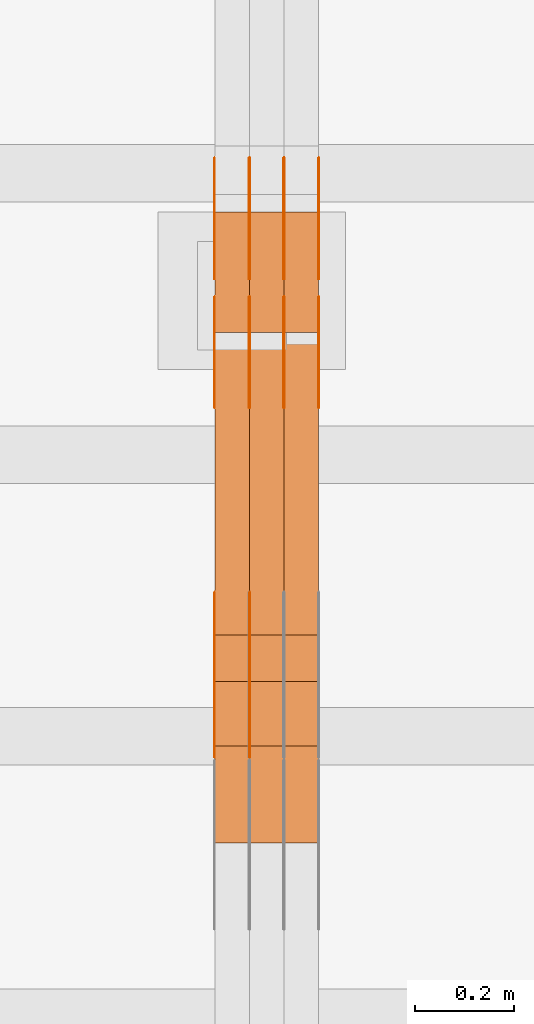
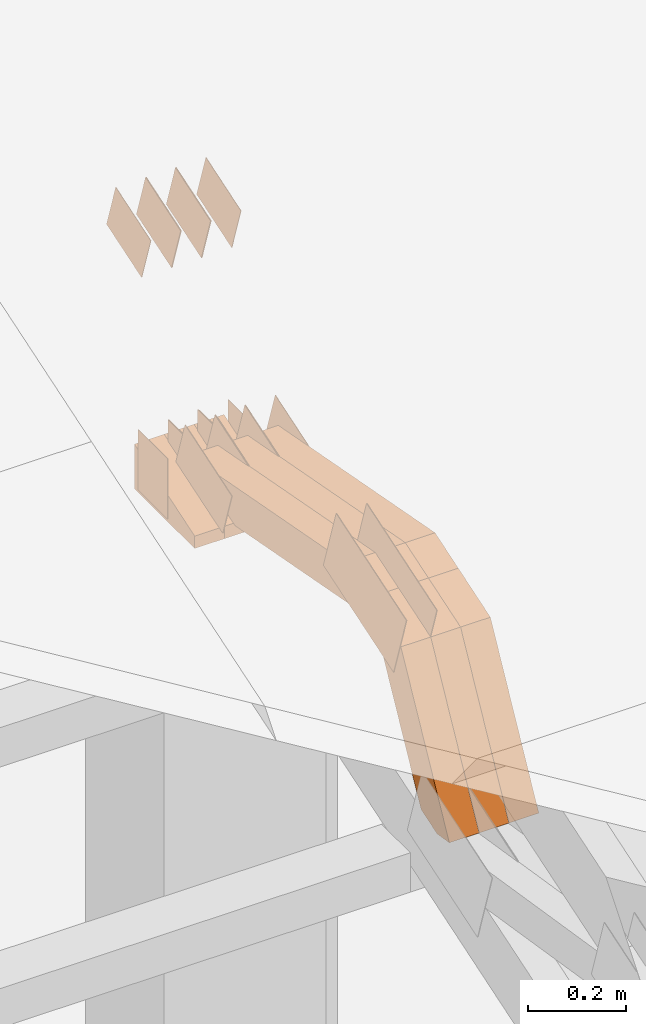
# One storey, part 95 of 385: 29 proxies.
"""IFC2X3 building model written with IfcOpenShell, lengths in millimetres."""

from ifc_helpers import new_model, entity, si_unit, converted_unit, derived_unit, direction, frame, frame_2d, origin, place, context, subcontext, project, spatial, polyline, rectangle, outline, extrude, source, transform, mapped, material, type_object, type_shapes, element, save


model = new_model("IFC2X3")

# Units and contexts
model_context = context("Model", 3, precision=0.01, world=origin(), true_north=direction((6.12303176911189e-17, 1.0)))
body_context = subcontext(model_context, "Body", "Model", "MODEL_VIEW")
ifc_project = project(units=[si_unit("LENGTHUNIT", "METRE", prefix="MILLI"), si_unit("AREAUNIT", "SQUARE_METRE"), si_unit("VOLUMEUNIT", "CUBIC_METRE"), converted_unit("PLANEANGLEUNIT", "DEGREE", entity("IfcRatioMeasure", 0.0174532925199433), si_unit("PLANEANGLEUNIT", "RADIAN"), dimensions=[0, 0, 0, 0, 0, 0, 0]), si_unit("MASSUNIT", "GRAM", prefix="KILO"), derived_unit("MASSDENSITYUNIT", [(si_unit("MASSUNIT", "GRAM", prefix="KILO"), 1), (si_unit("LENGTHUNIT", "METRE"), -3)]), si_unit("TIMEUNIT", "SECOND"), si_unit("FREQUENCYUNIT", "HERTZ"), si_unit("THERMODYNAMICTEMPERATUREUNIT", "DEGREE_CELSIUS"), derived_unit("THERMALTRANSMITTANCEUNIT", [(si_unit("MASSUNIT", "GRAM", prefix="KILO"), 1), (si_unit("THERMODYNAMICTEMPERATUREUNIT", "KELVIN"), -1), (si_unit("TIMEUNIT", "SECOND"), -3)]), derived_unit("VOLUMETRICFLOWRATEUNIT", [(si_unit("LENGTHUNIT", "METRE"), 3), (si_unit("TIMEUNIT", "SECOND"), -1)]), si_unit("ELECTRICCURRENTUNIT", "AMPERE"), si_unit("ELECTRICVOLTAGEUNIT", "VOLT"), si_unit("POWERUNIT", "WATT"), si_unit("FORCEUNIT", "NEWTON", prefix="KILO"), si_unit("ILLUMINANCEUNIT", "LUX"), si_unit("LUMINOUSFLUXUNIT", "LUMEN"), si_unit("LUMINOUSINTENSITYUNIT", "CANDELA"), derived_unit("USERDEFINED", [(si_unit("MASSUNIT", "GRAM", prefix="KILO"), -1), (si_unit("LENGTHUNIT", "METRE"), -2), (si_unit("TIMEUNIT", "SECOND"), 3), (si_unit("LUMINOUSFLUXUNIT", "LUMEN"), 1)]), derived_unit("LINEARVELOCITYUNIT", [(si_unit("LENGTHUNIT", "METRE"), 1), (si_unit("TIMEUNIT", "SECOND"), -1)]), si_unit("PRESSUREUNIT", "PASCAL"), derived_unit("USERDEFINED", [(si_unit("LENGTHUNIT", "METRE"), -2), (si_unit("MASSUNIT", "GRAM", prefix="KILO"), 1), (si_unit("TIMEUNIT", "SECOND"), -2)])], contexts=[model_context])

# Site, building, storey
site_placement = place(None, origin())
site = spatial("IfcSite", under=ifc_project, at=site_placement, CompositionType="ELEMENT")
building_placement = place(site_placement, origin())
building = spatial("IfcBuilding", under=site, at=building_placement, CompositionType="ELEMENT")
storey_placement = place(building_placement, origin())
storey = spatial("IfcBuildingStorey", under=building, at=storey_placement, Name="Default", CompositionType="ELEMENT", Elevation=0.0)

# Proxies
ifc_material_1 = material(Name="IfcSurfaceStyle #207088")
building_element_proxy_type_1 = type_object("IfcBuildingElementProxyType", PredefinedType="NOTDEFINED", material=ifc_material_1)
shared_shape_1 = source(origin(), body_context, "Body", "SweptSolid", [
    extrude(outline(polyline([(-99.9997874178038, -60.0000528641967), (99.9998102700997, -60.0000528641967), (99.9998251396068, 60.0000528641967), (-99.9998479919027, 60.0000528641967), (-99.9997874178038, -60.0000528641967)])), frame((99.9999918898597, 60.0000528641967, 0.0), z_axis=(0.0, 0.0, 1.0), x_axis=(-1.0, 0.0, 0.0)), (0.0, 0.0, 1.0), 1.3),
])
type_shapes(building_element_proxy_type_1, [shared_shape_1])
proxy_1_placement = place(building_placement, frame((15386.3, 11991.9568177725, 3072.52282247925), z_axis=(-1.0, 0.0, 0.0), x_axis=(0.0, 0.951056516295124, 0.309016994375039)))
element("IfcBuildingElementProxy", 1, at=proxy_1_placement, inside=storey, type_object=building_element_proxy_type_1, material=ifc_material_1, context=body_context, shape_type="MappedRepresentation", body=[
    mapped(shared_shape_1, transform((0.0, 0.0, 0.0), scale=1.0)),
])
ifc_material_2 = material(Name="IfcSurfaceStyle #207031")
building_element_proxy_type_2 = type_object("IfcBuildingElementProxyType", PredefinedType="NOTDEFINED", material=ifc_material_2)
shared_shape_2 = source(origin(), body_context, "Body", "SweptSolid", [
    extrude(outline(polyline([(-99.9997874178038, -60.0000528641967), (99.9998102700997, -60.0000528641967), (99.9998251396068, 60.0000528641967), (-99.9998479919027, 60.0000528641967), (-99.9997874178038, -60.0000528641967)])), frame((99.9999918898597, 60.0000528641967, 0.0), z_axis=(0.0, 0.0, 1.0), x_axis=(-1.0, 0.0, 0.0)), (0.0, 0.0, 1.0), 1.3),
])
type_shapes(building_element_proxy_type_2, [shared_shape_2])
proxy_2_placement = place(building_placement, frame((15315.0, 11991.9568177725, 3072.52282247925), z_axis=(-1.0, 0.0, 0.0), x_axis=(0.0, 0.951056516295124, 0.309016994375039)))
element("IfcBuildingElementProxy", 2, at=proxy_2_placement, inside=storey, type_object=building_element_proxy_type_2, material=ifc_material_2, context=body_context, shape_type="MappedRepresentation", body=[
    mapped(shared_shape_2, transform((0.0, 0.0, 0.0), scale=1.0)),
])
ifc_material_3 = material(Name="IfcSurfaceStyle #206974")
building_element_proxy_type_3 = type_object("IfcBuildingElementProxyType", PredefinedType="NOTDEFINED", material=ifc_material_3)
shared_shape_3 = source(origin(), body_context, "Body", "SweptSolid", [
    extrude(outline(polyline([(-99.9997874178038, -60.0000528641967), (99.9998102700997, -60.0000528641967), (99.9998251396068, 60.0000528641967), (-99.9998479919027, 60.0000528641967), (-99.9997874178038, -60.0000528641967)])), frame((99.9999918898597, 60.0000528641967, 0.0), z_axis=(0.0, 0.0, 1.0), x_axis=(-1.0, 0.0, 0.0)), (0.0, 0.0, 1.0), 1.3),
])
type_shapes(building_element_proxy_type_3, [shared_shape_3])
proxy_3_placement = place(building_placement, frame((15316.3, 11991.9568177725, 3072.52282247925), z_axis=(-1.0, 0.0, 0.0), x_axis=(0.0, 0.951056516295124, 0.309016994375039)))
element("IfcBuildingElementProxy", 3, at=proxy_3_placement, inside=storey, type_object=building_element_proxy_type_3, material=ifc_material_3, context=body_context, shape_type="MappedRepresentation", body=[
    mapped(shared_shape_3, transform((0.0, 0.0, 0.0), scale=1.0)),
])
ifc_material_4 = material(Name="IfcSurfaceStyle #206917")
building_element_proxy_type_4 = type_object("IfcBuildingElementProxyType", PredefinedType="NOTDEFINED", material=ifc_material_4)
shared_shape_4 = source(origin(), body_context, "Body", "SweptSolid", [
    extrude(outline(polyline([(-99.9997874178038, -60.0000528641967), (99.9998102700997, -60.0000528641967), (99.9998251396068, 60.0000528641967), (-99.9998479919027, 60.0000528641967), (-99.9997874178038, -60.0000528641967)])), frame((99.9999918898597, 60.0000528641967, 0.0), z_axis=(0.0, 0.0, 1.0), x_axis=(-1.0, 0.0, 0.0)), (0.0, 0.0, 1.0), 1.29999999999998),
])
type_shapes(building_element_proxy_type_4, [shared_shape_4])
proxy_4_placement = place(building_placement, frame((15245.0, 11991.9568177725, 3072.52282247925), z_axis=(-1.0, 0.0, 0.0), x_axis=(0.0, 0.951056516295124, 0.309016994375039)))
element("IfcBuildingElementProxy", 4, at=proxy_4_placement, inside=storey, type_object=building_element_proxy_type_4, material=ifc_material_4, context=body_context, shape_type="MappedRepresentation", body=[
    mapped(shared_shape_4, transform((0.0, 0.0, 0.0), scale=1.0)),
])
ifc_material_5 = material(Name="IfcSurfaceStyle #206860")
building_element_proxy_type_5 = type_object("IfcBuildingElementProxyType", PredefinedType="NOTDEFINED", material=ifc_material_5)
shared_shape_5 = source(origin(), body_context, "Body", "SweptSolid", [
    extrude(outline(polyline([(-99.9997874178038, -60.0000528641967), (99.9998102700997, -60.0000528641967), (99.9998251396068, 60.0000528641967), (-99.9998479919027, 60.0000528641967), (-99.9997874178038, -60.0000528641967)])), frame((99.9999918898597, 60.0000528641967, 0.0), z_axis=(0.0, 0.0, 1.0), x_axis=(-1.0, 0.0, 0.0)), (0.0, 0.0, 1.0), 1.29999999999998),
])
type_shapes(building_element_proxy_type_5, [shared_shape_5])
proxy_5_placement = place(building_placement, frame((15246.3, 11991.9568177725, 3072.52282247925), z_axis=(-1.0, 0.0, 0.0), x_axis=(0.0, 0.951056516295124, 0.309016994375039)))
element("IfcBuildingElementProxy", 5, at=proxy_5_placement, inside=storey, type_object=building_element_proxy_type_5, material=ifc_material_5, context=body_context, shape_type="MappedRepresentation", body=[
    mapped(shared_shape_5, transform((0.0, 0.0, 0.0), scale=1.0)),
])
ifc_material_6 = material(Name="IfcSurfaceStyle #206803")
building_element_proxy_type_6 = type_object("IfcBuildingElementProxyType", PredefinedType="NOTDEFINED", material=ifc_material_6)
shared_shape_6 = source(origin(), body_context, "Body", "SweptSolid", [
    extrude(outline(polyline([(-99.9997874178038, -60.0000528641967), (99.9998102700997, -60.0000528641967), (99.9998251396068, 60.0000528641967), (-99.9998479919027, 60.0000528641967), (-99.9997874178038, -60.0000528641967)])), frame((99.9999918898597, 60.0000528641967, 0.0), z_axis=(0.0, 0.0, 1.0), x_axis=(-1.0, 0.0, 0.0)), (0.0, 0.0, 1.0), 1.29999999999999),
])
type_shapes(building_element_proxy_type_6, [shared_shape_6])
proxy_6_placement = place(building_placement, frame((15175.0, 11991.9568177725, 3072.52282247925), z_axis=(-1.0, 0.0, 0.0), x_axis=(0.0, 0.951056516295124, 0.309016994375039)))
element("IfcBuildingElementProxy", 6, at=proxy_6_placement, inside=storey, type_object=building_element_proxy_type_6, material=ifc_material_6, context=body_context, shape_type="MappedRepresentation", body=[
    mapped(shared_shape_6, transform((0.0, 0.0, 0.0), scale=1.0)),
])
ifc_material_7 = material(Name="IfcSurfaceStyle #206746")
building_element_proxy_type_7 = type_object("IfcBuildingElementProxyType", PredefinedType="NOTDEFINED", material=ifc_material_7)
shared_shape_7 = source(origin(), body_context, "Body", "SweptSolid", [
    extrude(rectangle(XDim=150.0, YDim=119.999999999985, at=frame_2d((-7.105427357601e-15, 0.0), x_axis=(1.0, 0.0))), frame((75.0, 60.0, 0.0), z_axis=(0.0, 0.0, 1.0), x_axis=(-1.0, 0.0, 0.0)), (0.0, 0.0, 1.0), 1.3),
])
type_shapes(building_element_proxy_type_7, [shared_shape_7])
proxy_7_placement = place(building_placement, frame((15386.3, 12372.95703125, 3007.04687500001), z_axis=(-1.0, 0.0, 0.0), x_axis=(0.0, 0.0, -1.0)))
element("IfcBuildingElementProxy", 7, at=proxy_7_placement, inside=storey, type_object=building_element_proxy_type_7, material=ifc_material_7, context=body_context, shape_type="MappedRepresentation", body=[
    mapped(shared_shape_7, transform((0.0, 0.0, 0.0), scale=1.0)),
])
ifc_material_8 = material(Name="IfcSurfaceStyle #206689")
building_element_proxy_type_8 = type_object("IfcBuildingElementProxyType", PredefinedType="NOTDEFINED", material=ifc_material_8)
shared_shape_8 = source(origin(), body_context, "Body", "SweptSolid", [
    extrude(rectangle(XDim=150.0, YDim=119.999999999985, at=frame_2d((-7.105427357601e-15, 0.0), x_axis=(1.0, 0.0))), frame((75.0, 60.0, 0.0), z_axis=(0.0, 0.0, 1.0), x_axis=(-1.0, 0.0, 0.0)), (0.0, 0.0, 1.0), 1.3),
])
type_shapes(building_element_proxy_type_8, [shared_shape_8])
proxy_8_placement = place(building_placement, frame((15315.0, 12372.95703125, 3007.04687500001), z_axis=(-1.0, 0.0, 0.0), x_axis=(0.0, 0.0, -1.0)))
element("IfcBuildingElementProxy", 8, at=proxy_8_placement, inside=storey, type_object=building_element_proxy_type_8, material=ifc_material_8, context=body_context, shape_type="MappedRepresentation", body=[
    mapped(shared_shape_8, transform((0.0, 0.0, 0.0), scale=1.0)),
])
ifc_material_9 = material(Name="IfcSurfaceStyle #206632")
building_element_proxy_type_9 = type_object("IfcBuildingElementProxyType", PredefinedType="NOTDEFINED", material=ifc_material_9)
shared_shape_9 = source(origin(), body_context, "Body", "SweptSolid", [
    extrude(rectangle(XDim=150.0, YDim=119.999999999985, at=frame_2d((-7.105427357601e-15, 0.0), x_axis=(1.0, 0.0))), frame((75.0, 60.0, 0.0), z_axis=(0.0, 0.0, 1.0), x_axis=(-1.0, 0.0, 0.0)), (0.0, 0.0, 1.0), 1.3),
])
type_shapes(building_element_proxy_type_9, [shared_shape_9])
proxy_9_placement = place(building_placement, frame((15316.3, 12372.95703125, 3007.04687500001), z_axis=(-1.0, 0.0, 0.0), x_axis=(0.0, 0.0, -1.0)))
element("IfcBuildingElementProxy", 9, at=proxy_9_placement, inside=storey, type_object=building_element_proxy_type_9, material=ifc_material_9, context=body_context, shape_type="MappedRepresentation", body=[
    mapped(shared_shape_9, transform((0.0, 0.0, 0.0), scale=1.0)),
])
ifc_material_10 = material(Name="IfcSurfaceStyle #206575")
building_element_proxy_type_10 = type_object("IfcBuildingElementProxyType", PredefinedType="NOTDEFINED", material=ifc_material_10)
shared_shape_10 = source(origin(), body_context, "Body", "SweptSolid", [
    extrude(rectangle(XDim=150.0, YDim=119.999999999985, at=frame_2d((-7.105427357601e-15, 0.0), x_axis=(1.0, 0.0))), frame((75.0, 60.0, 0.0), z_axis=(0.0, 0.0, 1.0), x_axis=(-1.0, 0.0, 0.0)), (0.0, 0.0, 1.0), 1.29999999999999),
])
type_shapes(building_element_proxy_type_10, [shared_shape_10])
proxy_10_placement = place(building_placement, frame((15245.0, 12372.95703125, 3007.04687500001), z_axis=(-1.0, 0.0, 0.0), x_axis=(0.0, 0.0, -1.0)))
element("IfcBuildingElementProxy", 10, at=proxy_10_placement, inside=storey, type_object=building_element_proxy_type_10, material=ifc_material_10, context=body_context, shape_type="MappedRepresentation", body=[
    mapped(shared_shape_10, transform((0.0, 0.0, 0.0), scale=1.0)),
])
ifc_material_11 = material(Name="IfcSurfaceStyle #206518")
building_element_proxy_type_11 = type_object("IfcBuildingElementProxyType", PredefinedType="NOTDEFINED", material=ifc_material_11)
shared_shape_11 = source(origin(), body_context, "Body", "SweptSolid", [
    extrude(rectangle(XDim=150.0, YDim=119.999999999985, at=frame_2d((-7.105427357601e-15, 0.0), x_axis=(1.0, 0.0))), frame((75.0, 60.0, 0.0), z_axis=(0.0, 0.0, 1.0), x_axis=(-1.0, 0.0, 0.0)), (0.0, 0.0, 1.0), 1.29999999999999),
])
type_shapes(building_element_proxy_type_11, [shared_shape_11])
proxy_11_placement = place(building_placement, frame((15246.3, 12372.95703125, 3007.04687500001), z_axis=(-1.0, 0.0, 0.0), x_axis=(0.0, 0.0, -1.0)))
element("IfcBuildingElementProxy", 11, at=proxy_11_placement, inside=storey, type_object=building_element_proxy_type_11, material=ifc_material_11, context=body_context, shape_type="MappedRepresentation", body=[
    mapped(shared_shape_11, transform((0.0, 0.0, 0.0), scale=1.0)),
])
ifc_material_12 = material(Name="IfcSurfaceStyle #206461")
building_element_proxy_type_12 = type_object("IfcBuildingElementProxyType", PredefinedType="NOTDEFINED", material=ifc_material_12)
shared_shape_12 = source(origin(), body_context, "Body", "SweptSolid", [
    extrude(rectangle(XDim=150.0, YDim=119.999999999985, at=frame_2d((-7.105427357601e-15, 0.0), x_axis=(1.0, 0.0))), frame((75.0, 60.0, 0.0), z_axis=(0.0, 0.0, 1.0), x_axis=(-1.0, 0.0, 0.0)), (0.0, 0.0, 1.0), 1.29999999999999),
])
type_shapes(building_element_proxy_type_12, [shared_shape_12])
proxy_12_placement = place(building_placement, frame((15175.0, 12372.95703125, 3007.04687500001), z_axis=(-1.0, 0.0, 0.0), x_axis=(0.0, 0.0, -1.0)))
element("IfcBuildingElementProxy", 12, at=proxy_12_placement, inside=storey, type_object=building_element_proxy_type_12, material=ifc_material_12, context=body_context, shape_type="MappedRepresentation", body=[
    mapped(shared_shape_12, transform((0.0, 0.0, 0.0), scale=1.0)),
])
ifc_material_13 = material(Name="IfcSurfaceStyle #199564")
building_element_proxy_type_13 = type_object("IfcBuildingElementProxyType", PredefinedType="NOTDEFINED", material=ifc_material_13)
shared_shape_13 = source(origin(), body_context, "Body", "SweptSolid", [
    extrude(outline(polyline([(-74.9998754286244, -60.0000016373506), (74.9998605591063, -60.0000016373506), (74.9998754286244, 60.0000016373506), (-74.9998605591063, 60.0000016373506), (-74.9998754286244, -60.0000016373506)])), frame((74.9998754286244, 60.0000016373506, 0.0), z_axis=(0.0, 0.0, 1.0), x_axis=(-1.0, 0.0, 0.0)), (0.0, 0.0, 1.0), 1.3),
])
type_shapes(building_element_proxy_type_13, [shared_shape_13])
proxy_13_placement = place(building_placement, frame((15386.3, 12321.1620861463, 3506.17707344366), z_axis=(-1.0, 0.0, 0.0), x_axis=(0.0, 0.951056516295154, 0.309016994374948)))
element("IfcBuildingElementProxy", 13, at=proxy_13_placement, inside=storey, type_object=building_element_proxy_type_13, material=ifc_material_13, context=body_context, shape_type="MappedRepresentation", body=[
    mapped(shared_shape_13, transform((0.0, 0.0, 0.0), scale=1.0)),
])
ifc_material_14 = material(Name="IfcSurfaceStyle #199507")
building_element_proxy_type_14 = type_object("IfcBuildingElementProxyType", PredefinedType="NOTDEFINED", material=ifc_material_14)
shared_shape_14 = source(origin(), body_context, "Body", "SweptSolid", [
    extrude(outline(polyline([(-74.9998754286244, -60.0000016373506), (74.9998605591063, -60.0000016373506), (74.9998754286244, 60.0000016373506), (-74.9998605591063, 60.0000016373506), (-74.9998754286244, -60.0000016373506)])), frame((74.9998754286244, 60.0000016373506, 0.0), z_axis=(0.0, 0.0, 1.0), x_axis=(-1.0, 0.0, 0.0)), (0.0, 0.0, 1.0), 1.3),
])
type_shapes(building_element_proxy_type_14, [shared_shape_14])
proxy_14_placement = place(building_placement, frame((15315.0, 12321.1620861463, 3506.17707344366), z_axis=(-1.0, 0.0, 0.0), x_axis=(0.0, 0.951056516295154, 0.309016994374948)))
element("IfcBuildingElementProxy", 14, at=proxy_14_placement, inside=storey, type_object=building_element_proxy_type_14, material=ifc_material_14, context=body_context, shape_type="MappedRepresentation", body=[
    mapped(shared_shape_14, transform((0.0, 0.0, 0.0), scale=1.0)),
])
ifc_material_15 = material(Name="IfcSurfaceStyle #199450")
building_element_proxy_type_15 = type_object("IfcBuildingElementProxyType", PredefinedType="NOTDEFINED", material=ifc_material_15)
shared_shape_15 = source(origin(), body_context, "Body", "SweptSolid", [
    extrude(outline(polyline([(-74.9998754286244, -60.0000016373506), (74.9998605591063, -60.0000016373506), (74.9998754286244, 60.0000016373506), (-74.9998605591063, 60.0000016373506), (-74.9998754286244, -60.0000016373506)])), frame((74.9998754286244, 60.0000016373506, 0.0), z_axis=(0.0, 0.0, 1.0), x_axis=(-1.0, 0.0, 0.0)), (0.0, 0.0, 1.0), 1.3),
])
type_shapes(building_element_proxy_type_15, [shared_shape_15])
proxy_15_placement = place(building_placement, frame((15316.3, 12321.1620861463, 3506.17707344366), z_axis=(-1.0, 0.0, 0.0), x_axis=(0.0, 0.951056516295154, 0.309016994374948)))
element("IfcBuildingElementProxy", 15, at=proxy_15_placement, inside=storey, type_object=building_element_proxy_type_15, material=ifc_material_15, context=body_context, shape_type="MappedRepresentation", body=[
    mapped(shared_shape_15, transform((0.0, 0.0, 0.0), scale=1.0)),
])
ifc_material_16 = material(Name="IfcSurfaceStyle #199393")
building_element_proxy_type_16 = type_object("IfcBuildingElementProxyType", PredefinedType="NOTDEFINED", material=ifc_material_16)
shared_shape_16 = source(origin(), body_context, "Body", "SweptSolid", [
    extrude(outline(polyline([(-74.9998754286244, -60.0000016373506), (74.9998605591063, -60.0000016373506), (74.9998754286244, 60.0000016373506), (-74.9998605591063, 60.0000016373506), (-74.9998754286244, -60.0000016373506)])), frame((74.9998754286244, 60.0000016373506, 0.0), z_axis=(0.0, 0.0, 1.0), x_axis=(-1.0, 0.0, 0.0)), (0.0, 0.0, 1.0), 1.29999999999999),
])
type_shapes(building_element_proxy_type_16, [shared_shape_16])
proxy_16_placement = place(building_placement, frame((15245.0, 12321.1620861463, 3506.17707344366), z_axis=(-1.0, 0.0, 0.0), x_axis=(0.0, 0.951056516295154, 0.309016994374948)))
element("IfcBuildingElementProxy", 16, at=proxy_16_placement, inside=storey, type_object=building_element_proxy_type_16, material=ifc_material_16, context=body_context, shape_type="MappedRepresentation", body=[
    mapped(shared_shape_16, transform((0.0, 0.0, 0.0), scale=1.0)),
])
ifc_material_17 = material(Name="IfcSurfaceStyle #199336")
building_element_proxy_type_17 = type_object("IfcBuildingElementProxyType", PredefinedType="NOTDEFINED", material=ifc_material_17)
shared_shape_17 = source(origin(), body_context, "Body", "SweptSolid", [
    extrude(outline(polyline([(-74.9998754286244, -60.0000016373506), (74.9998605591063, -60.0000016373506), (74.9998754286244, 60.0000016373506), (-74.9998605591063, 60.0000016373506), (-74.9998754286244, -60.0000016373506)])), frame((74.9998754286244, 60.0000016373506, 0.0), z_axis=(0.0, 0.0, 1.0), x_axis=(-1.0, 0.0, 0.0)), (0.0, 0.0, 1.0), 1.29999999999999),
])
type_shapes(building_element_proxy_type_17, [shared_shape_17])
proxy_17_placement = place(building_placement, frame((15246.3, 12321.1620861463, 3506.17707344366), z_axis=(-1.0, 0.0, 0.0), x_axis=(0.0, 0.951056516295154, 0.309016994374948)))
element("IfcBuildingElementProxy", 17, at=proxy_17_placement, inside=storey, type_object=building_element_proxy_type_17, material=ifc_material_17, context=body_context, shape_type="MappedRepresentation", body=[
    mapped(shared_shape_17, transform((0.0, 0.0, 0.0), scale=1.0)),
])
ifc_material_18 = material(Name="IfcSurfaceStyle #199279")
building_element_proxy_type_18 = type_object("IfcBuildingElementProxyType", PredefinedType="NOTDEFINED", material=ifc_material_18)
shared_shape_18 = source(origin(), body_context, "Body", "SweptSolid", [
    extrude(outline(polyline([(-74.9998754286244, -60.0000016373506), (74.9998605591063, -60.0000016373506), (74.9998754286244, 60.0000016373506), (-74.9998605591063, 60.0000016373506), (-74.9998754286244, -60.0000016373506)])), frame((74.9998754286244, 60.0000016373506, 0.0), z_axis=(0.0, 0.0, 1.0), x_axis=(-1.0, 0.0, 0.0)), (0.0, 0.0, 1.0), 1.29999999999999),
])
type_shapes(building_element_proxy_type_18, [shared_shape_18])
proxy_18_placement = place(building_placement, frame((15175.0, 12321.1620861463, 3506.17707344366), z_axis=(-1.0, 0.0, 0.0), x_axis=(0.0, 0.951056516295154, 0.309016994374948)))
element("IfcBuildingElementProxy", 18, at=proxy_18_placement, inside=storey, type_object=building_element_proxy_type_18, material=ifc_material_18, context=body_context, shape_type="MappedRepresentation", body=[
    mapped(shared_shape_18, transform((0.0, 0.0, 0.0), scale=1.0)),
])
ifc_material_19 = material(Name="IfcSurfaceStyle #198652")
building_element_proxy_type_19 = type_object("IfcBuildingElementProxyType", PredefinedType="NOTDEFINED", material=ifc_material_19)
shared_shape_19 = source(origin(), body_context, "Body", "SweptSolid", [
    extrude(outline(polyline([(-150.000273478628, -84.0002987844282), (149.999198496832, -84.0002987844282), (150.000273478627, 84.0002987844282), (-149.999198496831, 84.0002987844282), (-150.000273478628, -84.0002987844282)])), frame((150.000273478627, 84.0002987844282, 0.0), z_axis=(0.0, 0.0, 1.0), x_axis=(-1.0, 0.0, 0.0)), (0.0, 0.0, 1.0), 1.29999999999998),
])
type_shapes(building_element_proxy_type_19, [shared_shape_19])
proxy_19_placement = place(building_placement, frame((15246.3, 11283.0116722926, 3194.09682266857), z_axis=(-1.0, 0.0, 0.0), x_axis=(0.0, 0.951056516295154, 0.309016994374948)))
element("IfcBuildingElementProxy", 19, at=proxy_19_placement, inside=storey, type_object=building_element_proxy_type_19, material=ifc_material_19, context=body_context, shape_type="MappedRepresentation", body=[
    mapped(shared_shape_19, transform((0.0, 0.0, 0.0), scale=1.0)),
])
ifc_material_20 = material(Name="IfcSurfaceStyle #198595")
building_element_proxy_type_20 = type_object("IfcBuildingElementProxyType", PredefinedType="NOTDEFINED", material=ifc_material_20)
shared_shape_20 = source(origin(), body_context, "Body", "SweptSolid", [
    extrude(outline(polyline([(-150.000273478628, -84.0002987844282), (149.999198496832, -84.0002987844282), (150.000273478627, 84.0002987844282), (-149.999198496831, 84.0002987844282), (-150.000273478628, -84.0002987844282)])), frame((150.000273478627, 84.0002987844282, 0.0), z_axis=(0.0, 0.0, 1.0), x_axis=(-1.0, 0.0, 0.0)), (0.0, 0.0, 1.0), 1.29999999999998),
])
type_shapes(building_element_proxy_type_20, [shared_shape_20])
proxy_20_placement = place(building_placement, frame((15175.0, 11283.0116722926, 3194.09682266857), z_axis=(-1.0, 0.0, 0.0), x_axis=(0.0, 0.951056516295154, 0.309016994374948)))
element("IfcBuildingElementProxy", 20, at=proxy_20_placement, inside=storey, type_object=building_element_proxy_type_20, material=ifc_material_20, context=body_context, shape_type="MappedRepresentation", body=[
    mapped(shared_shape_20, transform((0.0, 0.0, 0.0), scale=1.0)),
])
ifc_material_21 = material(Name="IfcSurfaceStyle #191104")
building_element_proxy_type_21 = type_object("IfcBuildingElementProxyType", Name="T1-E1 191102", PredefinedType="NOTDEFINED", material=ifc_material_21)
shared_shape_21 = source(origin(), body_context, "Body", "SweptSolid", [
    extrude(outline(polyline([(-75.1378173828004, -122.500000000005), (35.3350830078246, -122.500000000005), (35.3350830078004, 122.500000000005), (4.46765136717545, 122.500000000005), (-75.1378173828004, -122.500000000005)])), frame((35.3350830078246, 122.500000104877, 0.0), z_axis=(0.0, 0.0, 1.0), x_axis=(-1.0, 0.0, 0.0)), (0.0, 0.0, 1.0), 70.0),
])
type_shapes(building_element_proxy_type_21, [shared_shape_21])
proxy_21_placement = place(building_placement, frame((15385.0, 12145.0, 2849.54565429685), z_axis=(-1.0, 0.0, 0.0), x_axis=(0.0, 0.0, 1.0)))
element("IfcBuildingElementProxy", 21, at=proxy_21_placement, inside=storey, type_object=building_element_proxy_type_21, material=ifc_material_21, Name="T1-E1", context=body_context, shape_type="MappedRepresentation", body=[
    mapped(shared_shape_21, transform((0.0, 0.0, 0.0), scale=1.0)),
])
ifc_material_22 = material(Name="IfcSurfaceStyle #191047")
building_element_proxy_type_22 = type_object("IfcBuildingElementProxyType", Name="T1-E1 191045", PredefinedType="NOTDEFINED", material=ifc_material_22)
shared_shape_22 = source(origin(), body_context, "Body", "SweptSolid", [
    extrude(outline(polyline([(-75.1378173828004, -122.500000000005), (35.3350830078246, -122.500000000005), (35.3350830078004, 122.500000000005), (4.46765136717545, 122.500000000005), (-75.1378173828004, -122.500000000005)])), frame((35.3350830078246, 122.500000104877, 0.0), z_axis=(0.0, 0.0, 1.0), x_axis=(-1.0, 0.0, 0.0)), (0.0, 0.0, 1.0), 70.0),
])
type_shapes(building_element_proxy_type_22, [shared_shape_22])
proxy_22_placement = place(building_placement, frame((15315.0, 12145.0, 2849.54565429685), z_axis=(-1.0, 0.0, 0.0), x_axis=(0.0, 0.0, 1.0)))
element("IfcBuildingElementProxy", 22, at=proxy_22_placement, inside=storey, type_object=building_element_proxy_type_22, material=ifc_material_22, Name="T1-E1", context=body_context, shape_type="MappedRepresentation", body=[
    mapped(shared_shape_22, transform((0.0, 0.0, 0.0), scale=1.0)),
])
ifc_material_23 = material(Name="IfcSurfaceStyle #190990")
building_element_proxy_type_23 = type_object("IfcBuildingElementProxyType", Name="T1-E1 190988", PredefinedType="NOTDEFINED", material=ifc_material_23)
shared_shape_23 = source(origin(), body_context, "Body", "SweptSolid", [
    extrude(outline(polyline([(-75.1378173828004, -122.500000000005), (35.3350830078246, -122.500000000005), (35.3350830078004, 122.500000000005), (4.46765136717545, 122.500000000005), (-75.1378173828004, -122.500000000005)])), frame((35.3350830078246, 122.500000104877, 0.0), z_axis=(0.0, 0.0, 1.0), x_axis=(-1.0, 0.0, 0.0)), (0.0, 0.0, 1.0), 70.0),
])
type_shapes(building_element_proxy_type_23, [shared_shape_23])
proxy_23_placement = place(building_placement, frame((15245.0, 12145.0, 2849.54565429685), z_axis=(-1.0, 0.0, 0.0), x_axis=(0.0, 0.0, 1.0)))
element("IfcBuildingElementProxy", 23, at=proxy_23_placement, inside=storey, type_object=building_element_proxy_type_23, material=ifc_material_23, Name="T1-E1", context=body_context, shape_type="MappedRepresentation", body=[
    mapped(shared_shape_23, transform((0.0, 0.0, 0.0), scale=1.0)),
])
ifc_material_24 = material(Name="IfcSurfaceStyle #188584")
building_element_proxy_type_24 = type_object("IfcBuildingElementProxyType", Name="T1-W9 188582", PredefinedType="NOTDEFINED", material=ifc_material_24)
shared_shape_24 = source(origin(), body_context, "Body", "SweptSolid", [
    extrude(outline(polyline([(-287.457507623288, -47.5000268597988), (288.590479960635, -47.5000268597988), (273.55062971372, -2.33146189358546e-05), (186.625054999886, 47.5000385171083), (-461.308657050953, 47.5000385171083), (-287.457507623288, -47.5000268597988)])), frame((288.590945855618, 47.5000968036551, 0.0), z_axis=(0.0, 0.0, 1.0), x_axis=(-1.0, 0.0, 0.0)), (0.0, 0.0, 1.0), 70.0),
])
type_shapes(building_element_proxy_type_24, [shared_shape_24])
proxy_24_placement = place(building_placement, frame((15385.0, 11432.1200855376, 3205.63308612017), z_axis=(-1.0, 0.0, 0.0), x_axis=(0.0, 0.982760503514031, -0.184883186722992)))
element("IfcBuildingElementProxy", 24, at=proxy_24_placement, inside=storey, type_object=building_element_proxy_type_24, material=ifc_material_24, Name="T1-W9", context=body_context, shape_type="MappedRepresentation", body=[
    mapped(shared_shape_24, transform((0.0, 0.0, 0.0), scale=1.0)),
])
ifc_material_25 = material(Name="IfcSurfaceStyle #188518")
building_element_proxy_type_25 = type_object("IfcBuildingElementProxyType", Name="T1-W9 188516", PredefinedType="NOTDEFINED", material=ifc_material_25)
shared_shape_25 = source(origin(), body_context, "Body", "SweptSolid", [
    extrude(outline(polyline([(-287.457507623288, -47.5000268597988), (288.590479960635, -47.5000268597988), (273.55062971372, -2.33146189358546e-05), (186.625054999886, 47.5000385171083), (-461.308657050953, 47.5000385171083), (-287.457507623288, -47.5000268597988)])), frame((288.590945855618, 47.5000968036551, 0.0), z_axis=(0.0, 0.0, 1.0), x_axis=(-1.0, 0.0, 0.0)), (0.0, 0.0, 1.0), 70.0),
])
type_shapes(building_element_proxy_type_25, [shared_shape_25])
proxy_25_placement = place(building_placement, frame((15315.0, 11432.1200855376, 3205.63308612017), z_axis=(-1.0, 0.0, 0.0), x_axis=(0.0, 0.982760503514031, -0.184883186722992)))
element("IfcBuildingElementProxy", 25, at=proxy_25_placement, inside=storey, type_object=building_element_proxy_type_25, material=ifc_material_25, Name="T1-W9", context=body_context, shape_type="MappedRepresentation", body=[
    mapped(shared_shape_25, transform((0.0, 0.0, 0.0), scale=1.0)),
])
ifc_material_26 = material(Name="IfcSurfaceStyle #188452")
building_element_proxy_type_26 = type_object("IfcBuildingElementProxyType", Name="T1-W9 188450", PredefinedType="NOTDEFINED", material=ifc_material_26)
shared_shape_26 = source(origin(), body_context, "Body", "SweptSolid", [
    extrude(outline(polyline([(-287.457507623288, -47.5000268597988), (288.590479960635, -47.5000268597988), (273.55062971372, -2.33146189358546e-05), (186.625054999886, 47.5000385171083), (-461.308657050953, 47.5000385171083), (-287.457507623288, -47.5000268597988)])), frame((288.590945855618, 47.5000968036551, 0.0), z_axis=(0.0, 0.0, 1.0), x_axis=(-1.0, 0.0, 0.0)), (0.0, 0.0, 1.0), 70.0),
])
type_shapes(building_element_proxy_type_26, [shared_shape_26])
proxy_26_placement = place(building_placement, frame((15245.0, 11432.1200855376, 3205.63308612017), z_axis=(-1.0, 0.0, 0.0), x_axis=(0.0, 0.982760503514031, -0.184883186722992)))
element("IfcBuildingElementProxy", 26, at=proxy_26_placement, inside=storey, type_object=building_element_proxy_type_26, material=ifc_material_26, Name="T1-W9", context=body_context, shape_type="MappedRepresentation", body=[
    mapped(shared_shape_26, transform((0.0, 0.0, 0.0), scale=1.0)),
])
ifc_material_27 = material(Name="IfcSurfaceStyle #188188")
building_element_proxy_type_27 = type_object("IfcBuildingElementProxyType", Name="T1-W32 188186", PredefinedType="NOTDEFINED", material=ifc_material_27)
shared_shape_27 = source(origin(), body_context, "Body", "SweptSolid", [
    extrude(outline(polyline([(-312.414547135921, -47.5000544873059), (136.677011757652, -47.5000544873059), (186.250996577889, 0.000369497452627243), (202.753116295831, 47.4998697385796), (-213.26657749545, 47.4998697385796), (-312.414547135921, -47.5000544873059)])), frame((202.753376481939, 47.5001296985553, 0.0), z_axis=(0.0, 0.0, 1.0), x_axis=(-1.0, 0.0, 0.0)), (0.0, 0.0, 1.0), 70.0),
])
type_shapes(building_element_proxy_type_27, [shared_shape_27])
proxy_27_placement = place(building_placement, frame((15385.0, 11110.7808979007, 2747.18129017315), z_axis=(-1.0, 0.0, 0.0), x_axis=(0.0, 0.472919689385906, 0.881105537033526)))
element("IfcBuildingElementProxy", 27, at=proxy_27_placement, inside=storey, type_object=building_element_proxy_type_27, material=ifc_material_27, Name="T1-W32", context=body_context, shape_type="MappedRepresentation", body=[
    mapped(shared_shape_27, transform((0.0, 0.0, 0.0), scale=1.0)),
])
ifc_material_28 = material(Name="IfcSurfaceStyle #188122")
building_element_proxy_type_28 = type_object("IfcBuildingElementProxyType", Name="T1-W32 188120", PredefinedType="NOTDEFINED", material=ifc_material_28)
shared_shape_28 = source(origin(), body_context, "Body", "SweptSolid", [
    extrude(outline(polyline([(-312.414547135921, -47.5000544873059), (136.677011757652, -47.5000544873059), (186.250996577889, 0.000369497452627243), (202.753116295831, 47.4998697385796), (-213.26657749545, 47.4998697385796), (-312.414547135921, -47.5000544873059)])), frame((202.753376481939, 47.5001296985553, 0.0), z_axis=(0.0, 0.0, 1.0), x_axis=(-1.0, 0.0, 0.0)), (0.0, 0.0, 1.0), 70.0),
])
type_shapes(building_element_proxy_type_28, [shared_shape_28])
proxy_28_placement = place(building_placement, frame((15315.0, 11110.7808979007, 2747.18129017315), z_axis=(-1.0, 0.0, 0.0), x_axis=(0.0, 0.472919689385906, 0.881105537033526)))
element("IfcBuildingElementProxy", 28, at=proxy_28_placement, inside=storey, type_object=building_element_proxy_type_28, material=ifc_material_28, Name="T1-W32", context=body_context, shape_type="MappedRepresentation", body=[
    mapped(shared_shape_28, transform((0.0, 0.0, 0.0), scale=1.0)),
])
ifc_material_29 = material(Name="IfcSurfaceStyle #188056")
building_element_proxy_type_29 = type_object("IfcBuildingElementProxyType", Name="T1-W32 188054", PredefinedType="NOTDEFINED", material=ifc_material_29)
shared_shape_29 = source(origin(), body_context, "Body", "SweptSolid", [
    extrude(outline(polyline([(-312.414547135921, -47.5000544873059), (136.677011757652, -47.5000544873059), (186.250996577889, 0.000369497452627243), (202.753116295831, 47.4998697385796), (-213.26657749545, 47.4998697385796), (-312.414547135921, -47.5000544873059)])), frame((202.753376481939, 47.5001296985553, 0.0), z_axis=(0.0, 0.0, 1.0), x_axis=(-1.0, 0.0, 0.0)), (0.0, 0.0, 1.0), 70.0),
])
type_shapes(building_element_proxy_type_29, [shared_shape_29])
proxy_29_placement = place(building_placement, frame((15245.0, 11110.7808979007, 2747.18129017315), z_axis=(-1.0, 0.0, 0.0), x_axis=(0.0, 0.472919689385906, 0.881105537033526)))
element("IfcBuildingElementProxy", 29, at=proxy_29_placement, inside=storey, type_object=building_element_proxy_type_29, material=ifc_material_29, Name="T1-W32", context=body_context, shape_type="MappedRepresentation", body=[
    mapped(shared_shape_29, transform((0.0, 0.0, 0.0), scale=1.0)),
])

save(model, "model.ifc")
